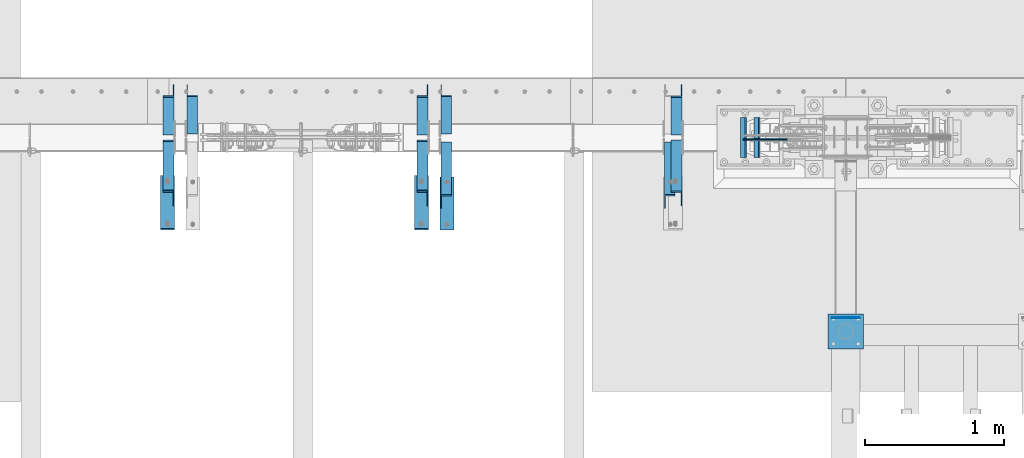
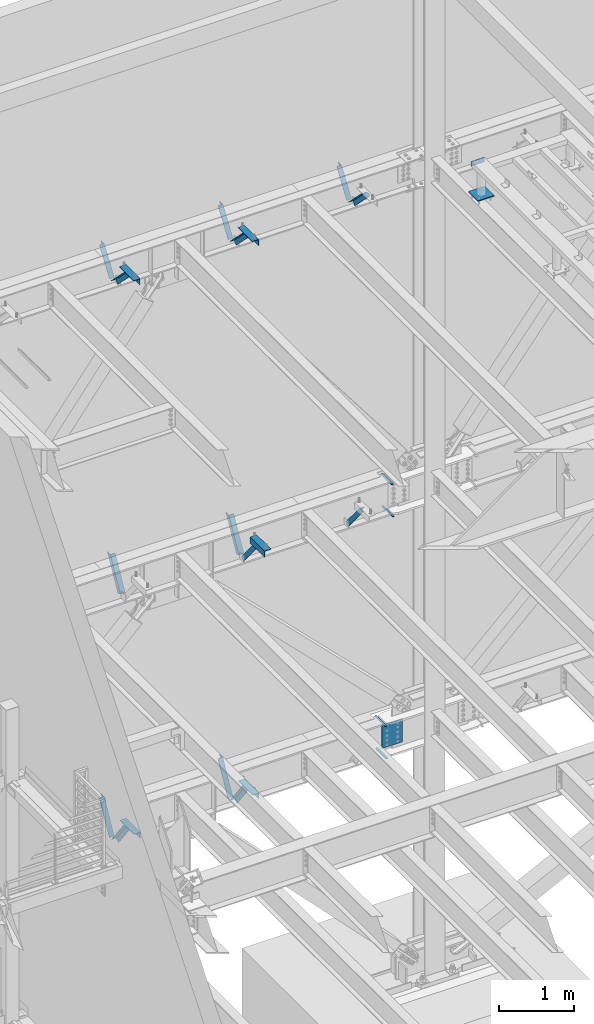
# One storey, part 883 of 1179: 14 members, 12 beams, 23 elements without a shape of their own.
"""IFC2X3 building model written with IfcOpenShell, lengths in millimetres."""

from ifc_helpers import new_model, si_unit, frame, origin_with_axes, place, context, subcontext, project, spatial, faceted_brep, material, type_object, element, aggregate, save


model = new_model("IFC2X3")

# Units and contexts
model_context = context("Model", 3, precision=1e-05, world=origin_with_axes())
body_context = subcontext(model_context, "Body", "Model", "MODEL_VIEW")
ifc_project = project(units=[si_unit("LENGTHUNIT", "METRE", prefix="MILLI"), si_unit("AREAUNIT", "SQUARE_METRE"), si_unit("VOLUMEUNIT", "CUBIC_METRE"), si_unit("MASSUNIT", "GRAM", prefix="KILO"), si_unit("TIMEUNIT", "SECOND"), si_unit("PLANEANGLEUNIT", "RADIAN"), si_unit("SOLIDANGLEUNIT", "STERADIAN"), si_unit("THERMODYNAMICTEMPERATUREUNIT", "DEGREE_CELSIUS"), si_unit("LUMINOUSINTENSITYUNIT", "LUMEN")], contexts=[model_context])

# Site, building, storey
site_placement = place(None, origin_with_axes())
site = spatial("IfcSite", under=ifc_project, at=site_placement, CompositionType="ELEMENT")
building_placement = place(site_placement, origin_with_axes())
building = spatial("IfcBuilding", under=site, at=building_placement, Name="Undefined", CompositionType="ELEMENT")
storey_placement = place(building_placement, origin_with_axes())
storey = spatial("IfcBuildingStorey", under=building, at=storey_placement, Name="Undefined", CompositionType="ELEMENT", Elevation=0.0)

# Assembly, beam
assembly_1_placement = place(storey_placement, origin_with_axes())
assembly_1 = element("IfcElementAssembly", 1, at=assembly_1_placement, inside=storey, Name="FRAME", AssemblyPlace="NOTDEFINED", PredefinedType="RIGID_FRAME")
ifc_material_1 = material(Name="STEEL/A36")
beam_type_1 = type_object("IfcBeamType", PredefinedType="NOTDEFINED")
beam_1_placement = place(assembly_1_placement, frame((8178.8, 39900.3534873485, 13722.35), z_axis=(0.0, 0.0, 1.0), x_axis=(1.0, 0.0, 0.0)))
beam_1 = element("IfcBeam", 2, at=beam_1_placement, type_object=beam_type_1, material=ifc_material_1, Name="PLATE", context=body_context, shape_type="Brep", body=[
    faceted_brep([(0.0, 2.38149999999951, -38.0999999999985), (0.0, 2.38149999999951, 38.0999999999985), (203.199999999997, 2.38150000000314, 38.1000000000004), (203.199999999997, 2.38150000000314, -38.1000000000004), (0.0, -2.38149999999951, 38.0999999999985), (203.199999999997, -2.38150000000314, 38.1000000000004), (0.0, -2.38149999999951, -38.0999999999985), (203.199999999997, -2.38150000000314, -38.1000000000004)], [[[0, 1, 2, 3]], [[1, 4, 5, 2]], [[4, 6, 7, 5]], [[6, 0, 3, 7]], [[5, 7, 3, 2]], [[6, 4, 1, 0]]]),
])

# Assembly, member
assembly_2_placement = place(storey_placement, origin_with_axes())
assembly_2 = element("IfcElementAssembly", 3, at=assembly_2_placement, inside=storey, Name="ANGLE", AssemblyPlace="NOTDEFINED", PredefinedType="RIGID_FRAME")
member_type = type_object("IfcMemberType", Name="L3X3X1/4", PredefinedType="NOTDEFINED")
member_1_placement = place(assembly_2_placement, frame((7061.2, 41248.3636551318, 12707.4244380128), z_axis=(0.0, 0.821716663099518, -0.569896241069015), x_axis=(0.0, 0.569896241069016, 0.821716663099518)))
member_1 = element("IfcMember", 4, at=member_1_placement, type_object=member_type, material=ifc_material_1, Name="ANGLE", ObjectType="L3X3X1/4", context=body_context, shape_type="Brep", body=[
    faceted_brep([(0.0, -38.0999999999985, -38.0999999999999), (0.0, -38.0999999999985, -31.75), (0.0, 31.75, -31.75), (0.0, 31.75, 38.1000000000004), (0.0, 38.0999999999985, 38.0999999999999), (0.0, 38.0999999999985, -38.0999999999999), (527.418547333735, 31.75, 38.0999999993364), (527.418547333735, 38.1000000000004, 38.0999999993364), (474.570533511644, 38.1000000000004, -38.1000000006607), (474.570533511644, -38.1000000000004, -38.1000000006607), (478.974534663488, -38.1000000000004, -31.7500000006621), (478.974534663488, 31.75, -31.7500000006621)], [[[0, 1, 2, 3, 4, 5]], [[4, 3, 6, 7]], [[5, 4, 7, 8]], [[0, 5, 8, 9]], [[1, 0, 9, 10]], [[2, 1, 10, 11]], [[3, 2, 11, 6]], [[10, 9, 8, 7, 6, 11]]]),
])
aggregate(assembly_2, [member_1])

assembly_3_placement = place(storey_placement, origin_with_axes())
assembly_3 = element("IfcElementAssembly", 5, at=assembly_3_placement, inside=storey, Name="ANGLE", AssemblyPlace="NOTDEFINED", PredefinedType="RIGID_FRAME")
member_2_placement = place(assembly_3_placement, frame((7061.20000000001, 40704.7386537899, 13150.1502196526), z_axis=(0.0, -0.706388288025418, -0.707824545025474), x_axis=(0.0, 0.707824545025473, -0.706388288025419)))
member_2 = element("IfcMember", 6, at=member_2_placement, type_object=member_type, material=ifc_material_1, Name="ANGLE", ObjectType="L3X3X1/4", context=body_context, shape_type="Brep", body=[
    faceted_brep([(634.184990526992, 31.75, 38.0999999999767), (634.184990526996, 31.75, -31.7499999999636), (634.184990526996, -38.0999999999985, -31.7499999999636), (634.184990526996, -38.0999999999985, -38.0999999999549), (634.184990526996, 38.0999999999985, -38.0999999999549), (634.184990526992, 38.0999999999985, 38.0999999999767), (113.596638248473, -38.0999999999985, -38.0999999999549), (113.596638248473, 38.0999999999985, -38.0999999999549), (37.2417053522113, 38.0999999999985, 38.0999999999694), (37.2417053522113, 31.75, 38.0999999999694), (107.233727173789, 31.75, -31.7499999999709), (107.233727173789, -38.0999999999985, -31.7499999999709)], [[[0, 1, 2, 3, 4, 5]], [[4, 3, 6, 7]], [[5, 4, 7, 8]], [[0, 5, 8, 9]], [[1, 0, 9, 10]], [[2, 1, 10, 11]], [[3, 2, 11, 6]], [[10, 9, 8, 7, 6, 11]]]),
])
aggregate(assembly_3, [member_2])

assembly_4_placement = place(storey_placement, origin_with_axes())
assembly_4 = element("IfcElementAssembly", 7, at=assembly_4_placement, inside=storey, Name="ANGLE", AssemblyPlace="NOTDEFINED", PredefinedType="RIGID_FRAME")
member_3_placement = place(assembly_4_placement, frame((7012.22021260319, 41137.0679040265, 7518.83524528677), z_axis=(0.0, -0.767806695844832, -0.640681572870519), x_axis=(0.0, -0.640681572870519, 0.767806695844831)))
member_3 = element("IfcMember", 8, at=member_3_placement, type_object=member_type, material=ifc_material_1, Name="ANGLE", ObjectType="L3X3X1/4", context=body_context, shape_type="Brep", body=[
    faceted_brep([(0.0, 38.0999999999985, -38.0999999999999), (0.0, 38.0999999999985, 38.0999999999999), (655.633410548446, 38.1000000000004, 38.0999999994965), (592.049781860664, 38.1000000000004, -38.1000000005733), (0.0, 31.75, 38.1000000000004), (655.633410548446, 31.75, 38.0999999994965), (0.0, 31.75, -31.75), (597.348417584646, 31.75, -31.7500000005675), (0.0, -38.0999999999985, -31.75), (597.348417584646, -38.1000000000004, -31.7500000005675), (0.0, -38.0999999999985, -38.0999999999999), (592.049781860664, -38.1000000000004, -38.1000000005733)], [[[0, 1, 2, 3]], [[1, 4, 5, 2]], [[4, 6, 7, 5]], [[6, 8, 9, 7]], [[8, 10, 11, 9]], [[10, 0, 3, 11]], [[5, 7, 9, 11, 3, 2]], [[10, 8, 6, 4, 1, 0]]]),
])
aggregate(assembly_4, [member_3])

assembly_5_placement = place(storey_placement, origin_with_axes())
assembly_5 = element("IfcElementAssembly", 9, at=assembly_5_placement, inside=storey, Name="ANGLE", AssemblyPlace="NOTDEFINED", PredefinedType="RIGID_FRAME")
member_4_placement = place(assembly_5_placement, frame((5402.02978739681, 41137.0679040265, 7518.83524528677), z_axis=(0.0, -0.767806695844832, -0.640681572870519), x_axis=(0.0, -0.640681572870519, 0.767806695844831)))
member_4 = element("IfcMember", 10, at=member_4_placement, type_object=member_type, material=ifc_material_1, Name="ANGLE", ObjectType="L3X3X1/4", context=body_context, shape_type="Brep", body=[
    faceted_brep([(0.0, 38.0999999999985, -38.0999999999999), (0.0, 38.0999999999985, 38.0999999999999), (655.633410548446, 38.1000000000004, 38.0999999994965), (592.049781860664, 38.1000000000004, -38.1000000005733), (0.0, 31.75, 38.1000000000004), (655.633410548446, 31.75, 38.0999999994965), (0.0, 31.75, -31.75), (597.348417584646, 31.75, -31.7500000005675), (0.0, -38.0999999999985, -31.75), (597.348417584646, -38.1000000000004, -31.7500000005675), (0.0, -38.0999999999985, -38.0999999999999), (592.049781860664, -38.1000000000004, -38.1000000005733)], [[[0, 1, 2, 3]], [[1, 4, 5, 2]], [[4, 6, 7, 5]], [[6, 8, 9, 7]], [[8, 10, 11, 9]], [[10, 0, 3, 11]], [[5, 7, 9, 11, 3, 2]], [[10, 8, 6, 4, 1, 0]]]),
])
aggregate(assembly_5, [member_4])

assembly_6_placement = place(storey_placement, origin_with_axes())
assembly_6 = element("IfcElementAssembly", 11, at=assembly_6_placement, inside=storey, Name="ANGLE", AssemblyPlace="NOTDEFINED", PredefinedType="RIGID_FRAME")
member_5_placement = place(assembly_6_placement, frame((5402.02978739681, 41656.0, 8227.31342088179), z_axis=(0.0, 0.872675718014636, -0.488300206008189), x_axis=(0.0, -0.48830020600819, -0.872675718014636)))
member_5 = element("IfcMember", 12, at=member_5_placement, type_object=member_type, material=ifc_material_1, Name="ANGLE", ObjectType="L3X3X1/4", context=body_context, shape_type="Brep", body=[
    faceted_brep([(266.09845322503, 38.1000000000004, -38.1000000001477), (223.461222774196, 38.1000000000004, 38.0999999997293), (818.212094408347, 38.1000000000004, 38.0999999992346), (818.21209440822, 38.1000000000004, -38.100000000617), (223.461222774196, 31.75, 38.0999999997293), (818.212094408347, 31.75, 38.0999999992346), (262.545350687458, 31.75, -31.7500000001601), (818.212094408227, 31.75, -31.7500000006257), (262.545350687458, -38.1000000000004, -31.7500000001601), (818.212094408227, -38.1000000000004, -31.7500000006257), (266.09845322503, -38.1000000000004, -38.1000000001477), (818.21209440822, -38.1000000000004, -38.100000000617)], [[[0, 1, 2, 3]], [[1, 4, 5, 2]], [[4, 6, 7, 5]], [[6, 8, 9, 7]], [[8, 10, 11, 9]], [[10, 0, 3, 11]], [[5, 7, 9, 11, 3, 2]], [[10, 8, 6, 4, 1, 0]]]),
])
aggregate(assembly_6, [member_5])

assembly_7_placement = place(storey_placement, origin_with_axes())
assembly_7 = element("IfcElementAssembly", 13, at=assembly_7_placement, inside=storey, Name="ANGLE", AssemblyPlace="NOTDEFINED", PredefinedType="RIGID_FRAME")
member_6_placement = place(assembly_7_placement, frame((3573.22978739681, 41656.0, 8227.31342088179), z_axis=(0.0, 0.872675718014636, -0.488300206008189), x_axis=(0.0, -0.48830020600819, -0.872675718014636)))
member_6 = element("IfcMember", 14, at=member_6_placement, type_object=member_type, material=ifc_material_1, Name="ANGLE", ObjectType="L3X3X1/4", context=body_context, shape_type="Brep", body=[
    faceted_brep([(266.09845322503, 38.1000000000004, -38.1000000001477), (223.461222774196, 38.1000000000004, 38.0999999997293), (818.212094408347, 38.1000000000004, 38.0999999992346), (818.21209440822, 38.1000000000004, -38.100000000617), (223.461222774196, 31.75, 38.0999999997293), (818.212094408347, 31.75, 38.0999999992346), (262.545350687458, 31.75, -31.7500000001601), (818.212094408227, 31.75, -31.7500000006257), (262.545350687458, -38.1000000000004, -31.7500000001601), (818.212094408227, -38.1000000000004, -31.7500000006257), (266.09845322503, -38.1000000000004, -38.1000000001477), (818.21209440822, -38.1000000000004, -38.100000000617)], [[[0, 1, 2, 3]], [[1, 4, 5, 2]], [[4, 6, 7, 5]], [[6, 8, 9, 7]], [[8, 10, 11, 9]], [[10, 0, 3, 11]], [[5, 7, 9, 11, 3, 2]], [[10, 8, 6, 4, 1, 0]]]),
])
aggregate(assembly_7, [member_6])

assembly_8_placement = place(storey_placement, origin_with_axes())
assembly_8 = element("IfcElementAssembly", 15, at=assembly_8_placement, inside=storey, Name="ANGLE", AssemblyPlace="NOTDEFINED", PredefinedType="RIGID_FRAME")
member_7_placement = place(assembly_8_placement, frame((5232.40000000002, 40722.5022996856, 4156.39103856133), z_axis=(0.0, -0.797785167426298, -0.602941810322185), x_axis=(0.0, 0.602941810322187, -0.797785167426297)))
member_7 = element("IfcMember", 16, at=member_7_placement, type_object=member_type, material=ifc_material_1, Name="ANGLE", ObjectType="L3X3X1/4", context=body_context, shape_type="Brep", body=[
    faceted_brep([(110.776215380578, 38.1000000000004, -38.1000000000058), (53.1865686658894, 38.1000000000004, 38.1000000001659), (690.351875241478, 38.1000000000004, 38.1000000007261), (690.351875241598, 38.1000000000004, -38.0999999994892), (53.1865686658894, 31.75, 38.1000000001659), (690.351875241478, 31.75, 38.1000000007261), (105.977078154352, 31.75, -31.7499999999927), (690.351875241595, 31.75, -31.7499999994689), (105.977078154352, -38.1000000000004, -31.7499999999927), (690.351875241595, -38.1000000000004, -31.7499999994689), (110.776215380578, -38.1000000000004, -38.1000000000058), (690.351875241598, -38.1000000000004, -38.0999999994892)], [[[0, 1, 2, 3]], [[1, 4, 5, 2]], [[4, 6, 7, 5]], [[6, 8, 9, 7]], [[8, 10, 11, 9]], [[10, 0, 3, 11]], [[5, 7, 9, 11, 3, 2]], [[10, 8, 6, 4, 1, 0]]]),
])
aggregate(assembly_8, [member_7])

assembly_9_placement = place(storey_placement, origin_with_axes())
assembly_9 = element("IfcElementAssembly", 17, at=assembly_9_placement, inside=storey, Name="ANGLE", AssemblyPlace="NOTDEFINED", PredefinedType="RIGID_FRAME")
member_8_placement = place(assembly_9_placement, frame((5232.4, 41256.8365589201, 3601.33927004389), z_axis=(0.0, 0.873306509536275, -0.487171161299155), x_axis=(0.0, 0.487171161299156, 0.873306509536275)))
member_8 = element("IfcMember", 18, at=member_8_placement, type_object=member_type, material=ifc_material_1, Name="ANGLE", ObjectType="L3X3X1/4", context=body_context, shape_type="Brep", body=[
    faceted_brep([(0.0, 38.0999999999985, -38.0999999999999), (0.0, 38.0999999999985, 38.0999999999999), (594.661720177039, 38.1000000000004, 38.1000000011991), (552.153801037723, 38.1000000000004, -38.0999999989144), (0.0, 31.75, 38.1000000000004), (594.661720177039, 31.75, 38.1000000011991), (0.0, 31.75, -31.75), (555.696127632669, 31.75, -31.7499999988941), (0.0, -38.0999999999985, -31.75), (555.696127632669, -38.1000000000004, -31.7499999988941), (0.0, -38.0999999999985, -38.0999999999999), (552.153801037723, -38.1000000000004, -38.0999999989144)], [[[0, 1, 2, 3]], [[1, 4, 5, 2]], [[4, 6, 7, 5]], [[6, 8, 9, 7]], [[8, 10, 11, 9]], [[10, 0, 3, 11]], [[5, 7, 9, 11, 3, 2]], [[10, 8, 6, 4, 1, 0]]]),
])
aggregate(assembly_9, [member_8])

assembly_10_placement = place(storey_placement, origin_with_axes())
assembly_10 = element("IfcElementAssembly", 19, at=assembly_10_placement, inside=storey, Name="ANGLE", AssemblyPlace="NOTDEFINED", PredefinedType="RIGID_FRAME")
member_9_placement = place(assembly_10_placement, frame((3403.60000000002, 40722.5022996856, 4156.39103856133), z_axis=(0.0, -0.797785167426298, -0.602941810322185), x_axis=(0.0, 0.602941810322187, -0.797785167426297)))
member_9 = element("IfcMember", 20, at=member_9_placement, type_object=member_type, material=ifc_material_1, Name="ANGLE", ObjectType="L3X3X1/4", context=body_context, shape_type="Brep", body=[
    faceted_brep([(110.776215380578, 38.1000000000004, -38.1000000000058), (53.1865686658894, 38.1000000000004, 38.1000000001659), (690.351875241478, 38.1000000000004, 38.1000000007261), (690.351875241598, 38.1000000000004, -38.0999999994892), (53.1865686658894, 31.75, 38.1000000001659), (690.351875241478, 31.75, 38.1000000007261), (105.977078154352, 31.75, -31.7499999999927), (690.351875241595, 31.75, -31.7499999994689), (105.977078154352, -38.1000000000004, -31.7499999999927), (690.351875241595, -38.1000000000004, -31.7499999994689), (110.776215380578, -38.1000000000004, -38.1000000000058), (690.351875241598, -38.1000000000004, -38.0999999994892)], [[[0, 1, 2, 3]], [[1, 4, 5, 2]], [[4, 6, 7, 5]], [[6, 8, 9, 7]], [[8, 10, 11, 9]], [[10, 0, 3, 11]], [[5, 7, 9, 11, 3, 2]], [[10, 8, 6, 4, 1, 0]]]),
])
aggregate(assembly_10, [member_9])

assembly_11_placement = place(storey_placement, origin_with_axes())
assembly_11 = element("IfcElementAssembly", 21, at=assembly_11_placement, inside=storey, Name="ANGLE", AssemblyPlace="NOTDEFINED", PredefinedType="RIGID_FRAME")
member_10_placement = place(assembly_11_placement, frame((3403.6, 41256.8365589201, 3601.33927004389), z_axis=(0.0, 0.873306509536275, -0.487171161299155), x_axis=(0.0, 0.487171161299156, 0.873306509536275)))
member_10 = element("IfcMember", 22, at=member_10_placement, type_object=member_type, material=ifc_material_1, Name="ANGLE", ObjectType="L3X3X1/4", context=body_context, shape_type="Brep", body=[
    faceted_brep([(0.0, 38.0999999999985, -38.0999999999999), (0.0, 38.0999999999985, 38.0999999999999), (594.661720177039, 38.1000000000004, 38.1000000011991), (552.153801037723, 38.1000000000004, -38.0999999989144), (0.0, 31.75, 38.1000000000004), (594.661720177039, 31.75, 38.1000000011991), (0.0, 31.75, -31.75), (555.696127632669, 31.75, -31.7499999988941), (0.0, -38.0999999999985, -31.75), (555.696127632669, -38.1000000000004, -31.7499999988941), (0.0, -38.0999999999985, -38.0999999999999), (552.153801037723, -38.1000000000004, -38.0999999989144)], [[[0, 1, 2, 3]], [[1, 4, 5, 2]], [[4, 6, 7, 5]], [[6, 8, 9, 7]], [[8, 10, 11, 9]], [[10, 0, 3, 11]], [[5, 7, 9, 11, 3, 2]], [[10, 8, 6, 4, 1, 0]]]),
])
aggregate(assembly_11, [member_10])

assembly_12_placement = place(storey_placement, origin_with_axes())
assembly_12 = element("IfcElementAssembly", 23, at=assembly_12_placement, inside=storey, Name="ANGLE", AssemblyPlace="NOTDEFINED", PredefinedType="RIGID_FRAME")
member_11_placement = place(assembly_12_placement, frame((5232.40000000002, 40704.7386537875, 13150.1502196524), z_axis=(0.0, -0.706388288025418, -0.707824545025474), x_axis=(0.0, 0.707824545025473, -0.706388288025419)))
member_11 = element("IfcMember", 24, at=member_11_placement, type_object=member_type, material=ifc_material_1, Name="ANGLE", ObjectType="L3X3X1/4", context=body_context, shape_type="Brep", body=[
    faceted_brep([(634.184990526992, 31.75, 38.0999999999767), (634.184990526996, 31.75, -31.7499999999636), (634.184990526996, -38.0999999999985, -31.7499999999636), (634.184990526996, -38.0999999999985, -38.0999999999549), (634.184990526996, 38.0999999999985, -38.0999999999549), (634.184990526992, 38.0999999999985, 38.0999999999767), (113.596638248473, -38.0999999999985, -38.0999999999549), (113.596638248473, 38.0999999999985, -38.0999999999549), (37.2417053522113, 38.0999999999985, 38.0999999999694), (37.2417053522113, 31.75, 38.0999999999694), (107.233727173789, 31.75, -31.7499999999709), (107.233727173789, -38.0999999999985, -31.7499999999709)], [[[0, 1, 2, 3, 4, 5]], [[4, 3, 6, 7]], [[5, 4, 7, 8]], [[0, 5, 8, 9]], [[1, 0, 9, 10]], [[2, 1, 10, 11]], [[3, 2, 11, 6]], [[10, 9, 8, 7, 6, 11]]]),
])
aggregate(assembly_12, [member_11])

assembly_13_placement = place(storey_placement, origin_with_axes())
assembly_13 = element("IfcElementAssembly", 25, at=assembly_13_placement, inside=storey, Name="ANGLE", AssemblyPlace="NOTDEFINED", PredefinedType="RIGID_FRAME")
member_12_placement = place(assembly_13_placement, frame((5232.4, 41248.3636551321, 12707.4244380128), z_axis=(0.0, 0.821716663099518, -0.569896241069015), x_axis=(0.0, 0.569896241069016, 0.821716663099518)))
member_12 = element("IfcMember", 26, at=member_12_placement, type_object=member_type, material=ifc_material_1, Name="ANGLE", ObjectType="L3X3X1/4", context=body_context, shape_type="Brep", body=[
    faceted_brep([(0.0, -38.0999999999985, -38.0999999999999), (0.0, -38.0999999999985, -31.75), (0.0, 31.75, -31.75), (0.0, 31.75, 38.1000000000004), (0.0, 38.0999999999985, 38.0999999999999), (0.0, 38.0999999999985, -38.0999999999999), (527.418547333735, 31.75, 38.0999999993364), (527.418547333735, 38.1000000000004, 38.0999999993364), (474.570533511644, 38.1000000000004, -38.1000000006607), (474.570533511644, -38.1000000000004, -38.1000000006607), (478.974534663488, -38.1000000000004, -31.7500000006621), (478.974534663488, 31.75, -31.7500000006621)], [[[0, 1, 2, 3, 4, 5]], [[4, 3, 6, 7]], [[5, 4, 7, 8]], [[0, 5, 8, 9]], [[1, 0, 9, 10]], [[2, 1, 10, 11]], [[3, 2, 11, 6]], [[10, 9, 8, 7, 6, 11]]]),
])
aggregate(assembly_13, [member_12])

assembly_14_placement = place(storey_placement, origin_with_axes())
assembly_14 = element("IfcElementAssembly", 27, at=assembly_14_placement, inside=storey, Name="ANGLE", AssemblyPlace="NOTDEFINED", PredefinedType="RIGID_FRAME")
member_13_placement = place(assembly_14_placement, frame((3403.60000000002, 40704.7386537875, 13150.1502196524), z_axis=(0.0, -0.706388288025418, -0.707824545025474), x_axis=(0.0, 0.707824545025473, -0.706388288025419)))
member_13 = element("IfcMember", 28, at=member_13_placement, type_object=member_type, material=ifc_material_1, Name="ANGLE", ObjectType="L3X3X1/4", context=body_context, shape_type="Brep", body=[
    faceted_brep([(634.184990526992, 31.75, 38.0999999999767), (634.184990526996, 31.75, -31.7499999999636), (634.184990526996, -38.0999999999985, -31.7499999999636), (634.184990526996, -38.0999999999985, -38.0999999999549), (634.184990526996, 38.0999999999985, -38.0999999999549), (634.184990526992, 38.0999999999985, 38.0999999999767), (113.596638248473, -38.0999999999985, -38.0999999999549), (113.596638248473, 38.0999999999985, -38.0999999999549), (37.2417053522113, 38.0999999999985, 38.0999999999694), (37.2417053522113, 31.75, 38.0999999999694), (107.233727173789, 31.75, -31.7499999999709), (107.233727173789, -38.0999999999985, -31.7499999999709)], [[[0, 1, 2, 3, 4, 5]], [[4, 3, 6, 7]], [[5, 4, 7, 8]], [[0, 5, 8, 9]], [[1, 0, 9, 10]], [[2, 1, 10, 11]], [[3, 2, 11, 6]], [[10, 9, 8, 7, 6, 11]]]),
])
aggregate(assembly_14, [member_13])

assembly_15_placement = place(storey_placement, origin_with_axes())
assembly_15 = element("IfcElementAssembly", 29, at=assembly_15_placement, inside=storey, Name="ANGLE", AssemblyPlace="NOTDEFINED", PredefinedType="RIGID_FRAME")
member_14_placement = place(assembly_15_placement, frame((3403.6, 41248.3636551321, 12707.4244380128), z_axis=(0.0, 0.821716663099518, -0.569896241069015), x_axis=(0.0, 0.569896241069016, 0.821716663099518)))
member_14 = element("IfcMember", 30, at=member_14_placement, type_object=member_type, material=ifc_material_1, Name="ANGLE", ObjectType="L3X3X1/4", context=body_context, shape_type="Brep", body=[
    faceted_brep([(0.0, -38.0999999999985, -38.0999999999999), (0.0, -38.0999999999985, -31.75), (0.0, 31.75, -31.75), (0.0, 31.75, 38.1000000000004), (0.0, 38.0999999999985, 38.0999999999999), (0.0, 38.0999999999985, -38.0999999999999), (527.418547333735, 31.75, 38.0999999993364), (527.418547333735, 38.1000000000004, 38.0999999993364), (474.570533511644, 38.1000000000004, -38.1000000006607), (474.570533511644, -38.1000000000004, -38.1000000006607), (478.974534663488, -38.1000000000004, -31.7500000006621), (478.974534663488, 31.75, -31.7500000006621)], [[[0, 1, 2, 3, 4, 5]], [[4, 3, 6, 7]], [[5, 4, 7, 8]], [[0, 5, 8, 9]], [[1, 0, 9, 10]], [[2, 1, 10, 11]], [[3, 2, 11, 6]], [[10, 9, 8, 7, 6, 11]]]),
])
aggregate(assembly_15, [member_14])

# Assembly, beams
assembly_16_placement = place(storey_placement, origin_with_axes())
assembly_16 = element("IfcElementAssembly", 31, at=assembly_16_placement, inside=storey, Name="BEAM", AssemblyPlace="NOTDEFINED", PredefinedType="RIGID_FRAME")
ifc_material_2 = material(Name="STEEL/A572-GR.50")
beam_type_2 = type_object("IfcBeamType", PredefinedType="NOTDEFINED")
beam_2_placement = place(assembly_16_placement, frame((7663.05225322968, 41198.7999633791, 7459.6625), z_axis=(0.0, 1.0, 0.0), x_axis=(-1.0, 0.0, 0.0)))
beam_2 = element("IfcBeam", 32, at=beam_2_placement, type_object=beam_type_2, material=ifc_material_2, Name="PLATE", context=body_context, shape_type="Brep", body=[
    faceted_brep([(0.0, 4.76249999999982, -144.462500000001), (0.0, 4.76249999999982, 144.462500000001), (31.7500000000036, 4.76249999999982, 144.462500000001), (31.7500000000036, 4.76249999999982, -144.462500000001), (0.0, -4.76249999999982, 144.462500000001), (31.7500000000036, -4.76249999999982, 144.462500000001), (0.0, -4.76249999999982, -144.462500000001), (31.7500000000036, -4.76249999999982, -144.462500000001)], [[[0, 1, 2, 3]], [[1, 4, 5, 2]], [[4, 6, 7, 5]], [[6, 0, 3, 7]], [[5, 7, 3, 2]], [[6, 4, 1, 0]]]),
])
beam_3_placement = place(assembly_16_placement, frame((7651.94016979628, 41198.7999633791, 7984.72549025941), z_axis=(0.0, 1.0, 0.0), x_axis=(-1.0, 0.0, 0.0)))
beam_3 = element("IfcBeam", 33, at=beam_3_placement, type_object=beam_type_2, material=ifc_material_2, Name="PLATE", context=body_context, shape_type="Brep", body=[
    faceted_brep([(0.0, 4.76249999999982, -144.462500000001), (0.0, 4.76249999999982, 144.462500000001), (31.7500000000036, 4.76249999999982, 144.462500000001), (31.7500000000036, 4.76249999999982, -144.462500000001), (0.0, -4.76249999999982, 144.462500000001), (31.7500000000036, -4.76249999999982, 144.462500000001), (0.0, -4.76249999999982, -144.462500000001), (31.7500000000036, -4.76249999999982, -144.462500000001)], [[[0, 1, 2, 3]], [[1, 4, 5, 2]], [[4, 6, 7, 5]], [[6, 0, 3, 7]], [[5, 7, 3, 2]], [[6, 4, 1, 0]]]),
])
aggregate(assembly_16, [beam_2, beam_3])

assembly_17_placement = place(storey_placement, origin_with_axes())
assembly_17 = element("IfcElementAssembly", 34, at=assembly_17_placement, inside=storey, Name="BEAM", AssemblyPlace="NOTDEFINED", PredefinedType="RIGID_FRAME")
beam_4_placement = place(assembly_17_placement, frame((7566.21892998621, 41198.8000366209, 3548.0625), z_axis=(0.0, -1.0, 0.0), x_axis=(-1.0, 0.0, 0.0)))
beam_4 = element("IfcBeam", 35, at=beam_4_placement, type_object=beam_type_2, material=ifc_material_2, Name="PLATE", context=body_context, shape_type="Brep", body=[
    faceted_brep([(0.0, 4.76249999999982, -144.462500000001), (0.0, 4.76249999999982, 144.462500000001), (31.7500000000036, 4.76249999999982, 144.462500000001), (31.7500000000036, 4.76249999999982, -144.462500000001), (0.0, -4.76249999999982, 144.462500000001), (31.7500000000036, -4.76249999999982, 144.462500000001), (0.0, -4.76249999999982, -144.462500000001), (31.7500000000036, -4.76249999999982, -144.462500000001)], [[[0, 1, 2, 3]], [[1, 4, 5, 2]], [[4, 6, 7, 5]], [[6, 0, 3, 7]], [[5, 7, 3, 2]], [[6, 4, 1, 0]]]),
])
beam_5_placement = place(assembly_17_placement, frame((7555.0869148553, 41198.8000366209, 4073.128), z_axis=(0.0, -1.0, 0.0), x_axis=(-1.0, 0.0, 0.0)))
beam_5 = element("IfcBeam", 36, at=beam_5_placement, type_object=beam_type_2, material=ifc_material_2, Name="PLATE", context=body_context, shape_type="Brep", body=[
    faceted_brep([(0.0, 4.76249999999982, -144.462500000001), (0.0, 4.76249999999982, 144.462500000001), (31.7500000000036, 4.76249999999982, 144.462500000001), (31.7500000000036, 4.76249999999982, -144.462500000001), (0.0, -4.76249999999982, 144.462500000001), (31.7500000000036, -4.76249999999982, 144.462500000001), (0.0, -4.76249999999982, -144.462500000001), (31.7500000000036, -4.76249999999982, -144.462500000001)], [[[0, 1, 2, 3]], [[1, 4, 5, 2]], [[4, 6, 7, 5]], [[6, 0, 3, 7]], [[5, 7, 3, 2]], [[6, 4, 1, 0]]]),
])
aggregate(assembly_17, [beam_4, beam_5])

# Assembly, beam
assembly_18_placement = place(storey_placement, origin_with_axes())
assembly_18 = element("IfcElementAssembly", 37, at=assembly_18_placement, inside=storey, Name="ANGLE", AssemblyPlace="NOTDEFINED", PredefinedType="RIGID_FRAME")
beam_type_3 = type_object("IfcBeamType", Name="L4X4X1/4", PredefinedType="NOTDEFINED")
beam_6_placement = place(assembly_18_placement, frame((5408.37978739681, 40533.6375, 7962.9), z_axis=(1.0, 0.0, 0.0), x_axis=(0.0, 1.0, 0.0)))
beam_6 = element("IfcBeam", 38, at=beam_6_placement, type_object=beam_type_3, material=ifc_material_1, Name="ANGLE", ObjectType="L4X4X1/4", context=body_context, shape_type="Brep", body=[
    faceted_brep([(1.90993887372315e-11, 50.8000000000002, -50.8000000000002), (1.90993887372315e-11, 50.8000000000002, 50.8000000000002), (381.0, 50.8000000000002, 50.7999999999993), (381.0, 50.8000000000002, -50.7999999999993), (0.0, 44.4500000000007, 50.8000000000002), (381.0, 44.4499999999998, 50.7999999999993), (0.0, 44.4500000000007, -44.4499999999998), (381.0, 44.4499999999998, -44.4500000000007), (0.0, -50.7999999999993, -44.4499999999998), (381.0, -50.8000000000002, -44.4500000000007), (-1.81898940354586e-11, -50.7999999999997, -50.8000000000002), (381.0, -50.8000000000002, -50.7999999999993)], [[[0, 1, 2, 3]], [[1, 4, 5, 2]], [[4, 6, 7, 5]], [[6, 8, 9, 7]], [[8, 10, 11, 9]], [[10, 0, 3, 11]], [[5, 7, 9, 11, 3, 2]], [[10, 8, 6, 4, 1, 0]]]),
])
aggregate(assembly_18, [beam_6])

assembly_19_placement = place(storey_placement, origin_with_axes())
assembly_19 = element("IfcElementAssembly", 39, at=assembly_19_placement, inside=storey, Name="ANGLE", AssemblyPlace="NOTDEFINED", PredefinedType="RIGID_FRAME")
beam_7_placement = place(assembly_19_placement, frame((5226.04999999846, 40914.6375000007, 4051.30000000071), z_axis=(-1.0, 0.0, 0.0), x_axis=(0.0, -1.0, 0.0)))
beam_7 = element("IfcBeam", 40, at=beam_7_placement, type_object=beam_type_3, material=ifc_material_1, Name="ANGLE", ObjectType="L4X4X1/4", context=body_context, shape_type="Brep", body=[
    faceted_brep([(1.90993887372315e-11, 50.8000000000002, -50.8000000000002), (1.90993887372315e-11, 50.8000000000002, 50.8000000000002), (381.0, 50.8000000000002, 50.7999999999993), (381.0, 50.8000000000002, -50.7999999999993), (0.0, 44.4500000000007, 50.8000000000002), (381.0, 44.4499999999998, 50.7999999999993), (0.0, 44.4500000000007, -44.4499999999998), (381.0, 44.4499999999998, -44.4500000000007), (0.0, -50.7999999999993, -44.4499999999998), (381.0, -50.8000000000002, -44.4500000000007), (-1.81898940354586e-11, -50.7999999999997, -50.8000000000002), (381.0, -50.8000000000002, -50.7999999999993)], [[[0, 1, 2, 3]], [[1, 4, 5, 2]], [[4, 6, 7, 5]], [[6, 8, 9, 7]], [[8, 10, 11, 9]], [[10, 0, 3, 11]], [[5, 7, 9, 11, 3, 2]], [[10, 8, 6, 4, 1, 0]]]),
])
aggregate(assembly_19, [beam_7])

assembly_20_placement = place(storey_placement, origin_with_axes())
assembly_20 = element("IfcElementAssembly", 41, at=assembly_20_placement, inside=storey, Name="ANGLE", AssemblyPlace="NOTDEFINED", PredefinedType="RIGID_FRAME")
beam_8_placement = place(assembly_20_placement, frame((3397.24999999846, 40914.6375000007, 4051.30000000071), z_axis=(-1.0, 0.0, 0.0), x_axis=(0.0, -1.0, 0.0)))
beam_8 = element("IfcBeam", 42, at=beam_8_placement, type_object=beam_type_3, material=ifc_material_1, Name="ANGLE", ObjectType="L4X4X1/4", context=body_context, shape_type="Brep", body=[
    faceted_brep([(1.90993887372315e-11, 50.8000000000002, -50.8000000000002), (1.90993887372315e-11, 50.8000000000002, 50.8000000000002), (381.0, 50.8000000000002, 50.7999999999993), (381.0, 50.8000000000002, -50.7999999999993), (0.0, 44.4500000000007, 50.8000000000002), (381.0, 44.4499999999998, 50.7999999999993), (0.0, 44.4500000000007, -44.4499999999998), (381.0, 44.4499999999998, -44.4500000000007), (0.0, -50.7999999999993, -44.4499999999998), (381.0, -50.8000000000002, -44.4500000000007), (-1.81898940354586e-11, -50.7999999999997, -50.8000000000002), (381.0, -50.8000000000002, -50.7999999999993)], [[[0, 1, 2, 3]], [[1, 4, 5, 2]], [[4, 6, 7, 5]], [[6, 8, 9, 7]], [[8, 10, 11, 9]], [[10, 0, 3, 11]], [[5, 7, 9, 11, 3, 2]], [[10, 8, 6, 4, 1, 0]]]),
])
aggregate(assembly_20, [beam_8])

assembly_21_placement = place(storey_placement, origin_with_axes())
assembly_21 = element("IfcElementAssembly", 43, at=assembly_21_placement, inside=storey, Name="ANGLE", AssemblyPlace="NOTDEFINED", PredefinedType="RIGID_FRAME")
beam_9_placement = place(assembly_21_placement, frame((5226.04999999795, 40924.1624999532, 13068.3), z_axis=(-1.0, 0.0, 0.0), x_axis=(0.0, -1.0, 0.0)))
beam_9 = element("IfcBeam", 44, at=beam_9_placement, type_object=beam_type_3, material=ifc_material_1, Name="ANGLE", ObjectType="L4X4X1/4", context=body_context, shape_type="Brep", body=[
    faceted_brep([(1.90993887372315e-11, 50.8000000000002, -50.8000000000002), (1.90993887372315e-11, 50.8000000000002, 50.8000000000002), (381.0, 50.8000000000002, 50.7999999999993), (381.0, 50.8000000000002, -50.7999999999993), (0.0, 44.4500000000007, 50.8000000000002), (381.0, 44.4499999999998, 50.7999999999993), (0.0, 44.4500000000007, -44.4499999999998), (381.0, 44.4499999999998, -44.4500000000007), (0.0, -50.7999999999993, -44.4499999999998), (381.0, -50.8000000000002, -44.4500000000007), (-1.81898940354586e-11, -50.7999999999997, -50.8000000000002), (381.0, -50.8000000000002, -50.7999999999993)], [[[0, 1, 2, 3]], [[1, 4, 5, 2]], [[4, 6, 7, 5]], [[6, 8, 9, 7]], [[8, 10, 11, 9]], [[10, 0, 3, 11]], [[5, 7, 9, 11, 3, 2]], [[10, 8, 6, 4, 1, 0]]]),
])
aggregate(assembly_21, [beam_9])

assembly_22_placement = place(storey_placement, origin_with_axes())
assembly_22 = element("IfcElementAssembly", 45, at=assembly_22_placement, inside=storey, Name="ANGLE", AssemblyPlace="NOTDEFINED", PredefinedType="RIGID_FRAME")
beam_10_placement = place(assembly_22_placement, frame((3397.24999999708, 40924.1624999533, 13068.3), z_axis=(-1.0, 0.0, 0.0), x_axis=(0.0, -1.0, 0.0)))
beam_10 = element("IfcBeam", 46, at=beam_10_placement, type_object=beam_type_3, material=ifc_material_1, Name="ANGLE", ObjectType="L4X4X1/4", context=body_context, shape_type="Brep", body=[
    faceted_brep([(1.90993887372315e-11, 50.8000000000002, -50.8000000000002), (1.90993887372315e-11, 50.8000000000002, 50.8000000000002), (381.0, 50.8000000000002, 50.7999999999993), (381.0, 50.8000000000002, -50.7999999999993), (0.0, 44.4500000000007, 50.8000000000002), (381.0, 44.4499999999998, 50.7999999999993), (0.0, 44.4500000000007, -44.4499999999998), (381.0, 44.4499999999998, -44.4500000000007), (0.0, -50.7999999999993, -44.4499999999998), (381.0, -50.8000000000002, -44.4500000000007), (-1.81898940354586e-11, -50.7999999999997, -50.8000000000002), (381.0, -50.8000000000002, -50.7999999999993)], [[[0, 1, 2, 3]], [[1, 4, 5, 2]], [[4, 6, 7, 5]], [[6, 8, 9, 7]], [[8, 10, 11, 9]], [[10, 0, 3, 11]], [[5, 7, 9, 11, 3, 2]], [[10, 8, 6, 4, 1, 0]]]),
])
aggregate(assembly_22, [beam_10])

assembly_23_placement = place(storey_placement, origin_with_axes())
assembly_23 = element("IfcElementAssembly", 47, at=assembly_23_placement, inside=storey, Name="PLATE", AssemblyPlace="NOTDEFINED", PredefinedType="RIGID_FRAME")
beam_type_4 = type_object("IfcBeamType", PredefinedType="NOTDEFINED")
beam_11_placement = place(assembly_23_placement, frame((7542.3869148553, 41184.5125, 3827.46249389647), z_axis=(0.0, 0.0, -1.0), x_axis=(1.0, 0.0, 0.0)))
beam_11 = element("IfcBeam", 48, at=beam_11_placement, type_object=beam_type_4, material=ifc_material_2, Name="PLATE", context=body_context, shape_type="Brep", body=[
    faceted_brep([(0.0, 4.76249999999709, -190.5), (0.0, 4.76249999999709, 190.5), (317.499999999995, 4.76250000000073, 190.500000000051), (317.500000000042, 4.76250000000073, -190.499999999973), (0.0, -4.76249999999709, 190.5), (317.499999999995, -4.76250000000073, 190.500000000051), (0.0, -4.76249999999709, -190.5), (317.500000000042, -4.76250000000073, -190.499999999973)], [[[0, 1, 2, 3]], [[1, 4, 5, 2]], [[4, 6, 7, 5]], [[6, 0, 3, 7]], [[5, 7, 3, 2]], [[6, 4, 1, 0]]]),
])
aggregate(assembly_23, [beam_11])

# Beam
beam_type_5 = type_object("IfcBeamType", PredefinedType="NOTDEFINED")
beam_12_placement = place(assembly_1_placement, frame((8280.4, 39674.1344873485, 13258.8), z_axis=(1.0, 0.0, 0.0), x_axis=(0.0, 1.0, 0.0)))
beam_12 = element("IfcBeam", 49, at=beam_12_placement, type_object=beam_type_5, material=ifc_material_1, Name="PLATE", context=body_context, shape_type="Brep", body=[
    faceted_brep([(0.0, 6.35000000000036, -127.0), (0.0, 6.34999999999854, 127.0), (254.0, 6.35000000000036, 127.0), (254.0, 6.35000000000036, -127.0), (0.0, -6.34999999999854, 127.0), (254.0, -6.35000000000036, 127.0), (0.0, -6.35000000000036, -127.0), (254.0, -6.35000000000036, -127.0)], [[[0, 1, 2, 3]], [[1, 4, 5, 2]], [[4, 6, 7, 5]], [[6, 0, 3, 7]], [[5, 7, 3, 2]], [[6, 4, 1, 0]]]),
])

aggregate(assembly_1, [beam_1, beam_12])

save(model, "model.ifc")
